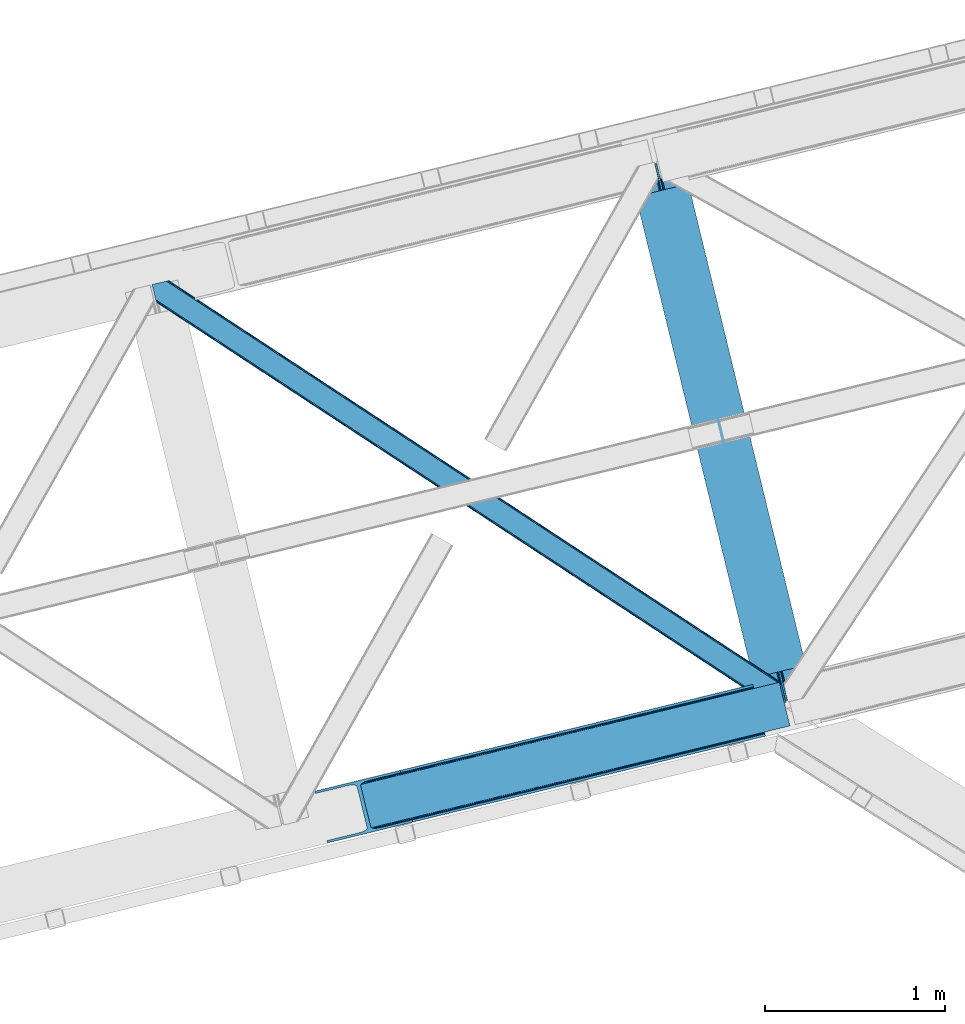
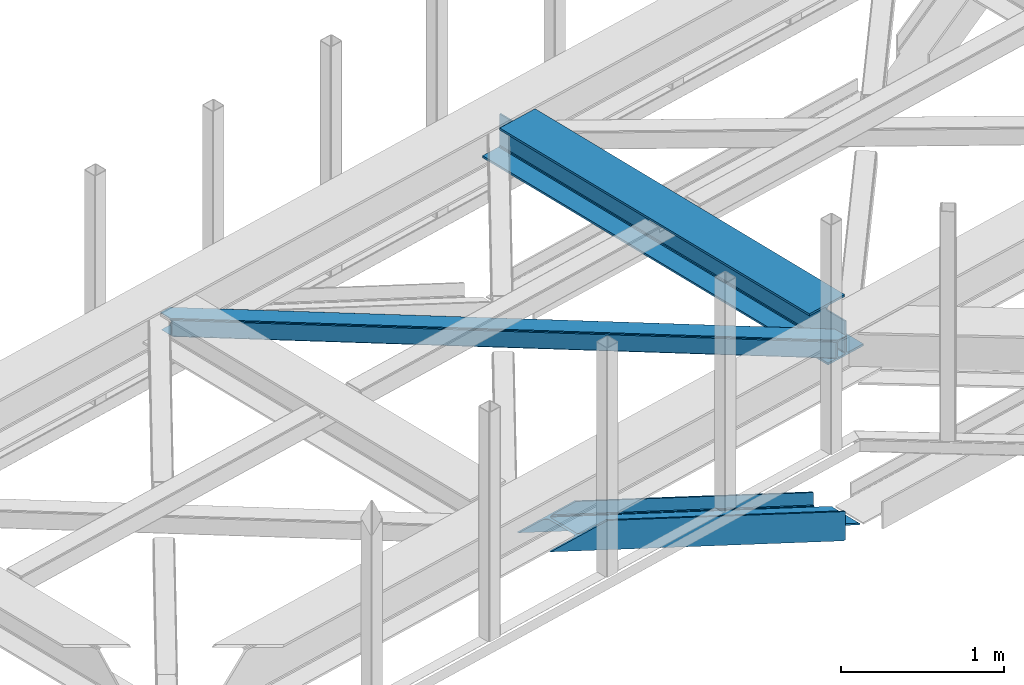
# One storey, part 56 of 66: 2 members, 1 beam.
"""IFC4 building model written with IfcOpenShell, lengths in millimetres."""

import ifcopenshell
import ifcopenshell.guid

model = None  # the IFC model being written
_history = None  # IfcOwnerHistory: only IFC2X3 demands one
_inside = {}  # id of a spatial element -> (the spatial element, [elements in it])
_under = {}  # id of a project, library or spatial element -> (it, [spatial elements below it])
_declared = {}  # id of a project -> (the project, [libraries it declares])
_typed = {}  # id of a type object -> (the type object, [elements of that type])
_made_of = {}  # id of a material, layer set ... -> (it, [elements and type objects made of it])


def new_model(schema):
    """Start an empty IFC model of exactly this schema.

    Asked for "IFC4X3", IfcOpenShell would pick the latest addendum, in which some entities
    have other attributes; the version numbers below select the first issue.
    IFC2X3 requires an IfcOwnerHistory on every rooted entity: one is made here for all.
    """
    global model, _history
    if schema == "IFC4X3":
        model = ifcopenshell.file(schema_version=(4, 3, 0, 0))
    else:
        model = ifcopenshell.file(schema=schema)
    _inside.clear()
    _under.clear()
    _declared.clear()
    _typed.clear()
    _made_of.clear()
    _history = None
    if model.schema == "IFC2X3":
        org = make("IfcOrganization", Name="unknown")
        user = make(
            "IfcPersonAndOrganization",
            ThePerson=make("IfcPerson", FamilyName="unknown"),
            TheOrganization=org,
        )
        app = make(
            "IfcApplication",
            ApplicationDeveloper=org,
            Version="unknown",
            ApplicationFullName="unknown",
            ApplicationIdentifier="unknown",
        )
        _history = make(
            "IfcOwnerHistory",
            OwningUser=user,
            OwningApplication=app,
            ChangeAction="ADDED",
            CreationDate=0,
        )
    return model


def make(cls, **values):
    """One entity of the class cls with the attributes given. An attribute that is None is left unset."""
    return model.create_entity(
        cls, **{name: value for name, value in values.items() if value is not None}
    )


def entity(cls, *values):
    """Any entity or typed value of the class cls, its attributes in the order of the schema. None: left unset."""
    e = model.create_entity(cls)
    for i, value in enumerate(values):
        if value is not None:
            e[i] = value
    return e


def rooted(cls, **values):
    """An entity with a GlobalId (a new one), such as an element, a storey or a relation."""
    return make(cls, GlobalId=ifcopenshell.guid.new(), OwnerHistory=_history, **values)


def si_unit(unit_type, name, prefix=None):
    """IfcSIUnit, for example si_unit("LENGTHUNIT", "METRE", prefix="MILLI")."""
    return make("IfcSIUnit", UnitType=unit_type, Prefix=prefix, Name=name)


def converted_unit(unit_type, name, factor, base, dimensions=None, offset=None):
    """IfcConversionBasedUnit, such as the inch: factor (a typed value) times the base unit."""
    return make(
        "IfcConversionBasedUnit"
        if offset is None
        else "IfcConversionBasedUnitWithOffset",
        ConversionOffset=offset,
        Dimensions=None
        if dimensions is None
        else entity("IfcDimensionalExponents", *dimensions),
        UnitType=unit_type,
        Name=name,
        ConversionFactor=make(
            "IfcMeasureWithUnit", ValueComponent=factor, UnitComponent=base
        ),
    )


def derived_unit(unit_type, elements):
    """IfcDerivedUnit: a product of units, each with its exponent."""
    return make(
        "IfcDerivedUnit",
        Elements=[
            make("IfcDerivedUnitElement", Unit=unit, Exponent=power)
            for unit, power in elements
        ],
        UnitType=unit_type,
    )


def assignment(units):
    """IfcUnitAssignment: the units of a project."""
    return None if units is None else make("IfcUnitAssignment", Units=units)


def point(xyz):
    """IfcCartesianPoint."""
    return None if xyz is None else make("IfcCartesianPoint", Coordinates=xyz)


def direction(xyz):
    """IfcDirection."""
    return None if xyz is None else make("IfcDirection", DirectionRatios=xyz)


def frame(location, z_axis=None, x_axis=None):
    """IfcAxis2Placement3D, a coordinate frame: its origin and axes. An axis left out is left unset."""
    return make(
        "IfcAxis2Placement3D",
        Location=point(location),
        Axis=direction(z_axis),
        RefDirection=direction(x_axis),
    )


def origin():
    """The frame at (0, 0, 0) with its axes left unset."""
    return frame((0.0, 0.0, 0.0))


def place(relative_to, where):
    """IfcLocalPlacement: puts the frame where relative to a parent placement (None: the world)."""
    return make(
        "IfcLocalPlacement", PlacementRelTo=relative_to, RelativePlacement=where
    )


def context(
    kind, dimensions, precision=None, world=None, true_north=None, identifier=None
):
    """IfcGeometricRepresentationContext, for example the 3D "Model" context."""
    return make(
        "IfcGeometricRepresentationContext",
        ContextIdentifier=identifier,
        ContextType=kind,
        CoordinateSpaceDimension=dimensions,
        Precision=precision,
        WorldCoordinateSystem=world,
        TrueNorth=true_north,
    )


def subcontext(parent, identifier, kind, view, scale=None):
    """IfcGeometricRepresentationSubContext, for example "Body" below "Model"."""
    return make(
        "IfcGeometricRepresentationSubContext",
        ContextIdentifier=identifier,
        ContextType=kind,
        ParentContext=parent,
        TargetScale=scale,
        TargetView=view,
    )


def project(units=None, contexts=None):
    """IfcProject with its units and contexts."""
    return rooted(
        "IfcProject",
        Name="project",
        RepresentationContexts=contexts,
        UnitsInContext=assignment(units),
    )


def spatial(cls, under=None, at=None, **own):
    """A site, building, storey or space (cls), placed at a placement, below another one or the project."""
    s = rooted(cls, ObjectPlacement=at, **own)
    if under is not None:
        _under.setdefault(under.id(), (under, []))[1].append(s)
    return s


def point_list(points):
    """IfcCartesianPointList2D or 3D."""
    cls = (
        "IfcCartesianPointList2D" if len(points[0]) == 2 else "IfcCartesianPointList3D"
    )
    return make(cls, CoordList=points)


def triangles(points, corners, closed=None, point_numbers=None):
    """IfcTriangulatedFaceSet: each triangle names its three corners, points numbered from 1."""
    return make(
        "IfcTriangulatedFaceSet",
        Coordinates=point_list(points),
        Closed=closed,
        CoordIndex=corners,
        PnIndex=point_numbers,
    )


def polygons(points, faces, closed=None, point_numbers=None):
    """IfcPolygonalFaceSet: a face is its outer loop, then its inner loops; points numbered from 1."""
    made = []
    for loops in faces:
        if len(loops) == 1:
            made.append(make("IfcIndexedPolygonalFace", CoordIndex=loops[0]))
        else:
            made.append(
                make(
                    "IfcIndexedPolygonalFaceWithVoids",
                    CoordIndex=loops[0],
                    InnerCoordIndices=loops[1:],
                )
            )
    return make(
        "IfcPolygonalFaceSet",
        Coordinates=point_list(points),
        Closed=closed,
        Faces=made,
        PnIndex=point_numbers,
    )


def shape(context_of_items, identifier, shape_type, items):
    """IfcShapeRepresentation: the items that make up one representation, for example the "Body"."""
    return make(
        "IfcShapeRepresentation",
        ContextOfItems=context_of_items,
        RepresentationIdentifier=identifier,
        RepresentationType=shape_type,
        Items=items,
    )


def material(Name=None, Category=None):
    """IfcMaterial."""
    return make("IfcMaterial", Name=Name, Category=Category)


def made_of(thing, what):
    """Note that an element or type object is made of a material, layer set ...; save() writes the relation."""
    if what is not None:
        _made_of.setdefault(what.id(), (what, []))[1].append(thing)
    return thing


def type_object(cls, material=None, **own):
    """A type object (cls), such as IfcWallType, which elements share."""
    return made_of(rooted(cls, **own), material)


def element(
    cls,
    number,
    at=None,
    inside=None,
    cuts=None,
    type_object=None,
    material=None,
    context=None,
    identifier="Body",
    shape_type=None,
    held_by="IfcProductDefinitionShape",
    body=None,
    shapes=None,
    **own,
):
    """One element of the class cls, such as IfcWall. Its Tag is "e" and its number.

    at: its placement. inside: the storey or other place that contains it. cuts: it is an
    opening in that element (IfcRelVoidsElement). A single representation is given by context,
    identifier, shape_type and body (its items); several are given by shapes. held_by: the class
    of the entity that holds the representations. save() writes the other relations.
    """
    e = rooted(cls, Tag="e%d" % number, ObjectPlacement=at, **own)
    if body is not None:
        shapes = [shape(context, identifier, shape_type, body)]
    if shapes is not None:
        e.Representation = make(held_by, Representations=shapes)
    if inside is not None:
        _inside.setdefault(inside.id(), (inside, []))[1].append(e)
    if cuts is not None:
        rooted(
            "IfcRelVoidsElement", RelatingBuildingElement=cuts, RelatedOpeningElement=e
        )
    if type_object is not None:
        _typed.setdefault(type_object.id(), (type_object, []))[1].append(e)
    return made_of(e, material)


def aggregate(whole, parts):
    """IfcRelAggregates: a whole, such as a stair, and the parts it consists of."""
    return rooted("IfcRelAggregates", RelatingObject=whole, RelatedObjects=parts)


def save(model, path):
    """Write the relations noted so far, then the file.

    IfcRelAggregates (storeys below a building ...), IfcRelContainedInSpatialStructure (elements
    in a storey), IfcRelDefinesByType, IfcRelAssociatesMaterial and IfcRelDeclares: one each for
    every whole, place, type object, material and project.
    """
    for whole, parts in _under.values():
        aggregate(whole, parts)
    for where, things in _inside.values():
        rooted(
            "IfcRelContainedInSpatialStructure",
            RelatedElements=things,
            RelatingStructure=where,
        )
    for kind, things in _typed.values():
        rooted("IfcRelDefinesByType", RelatedObjects=things, RelatingType=kind)
    for what, things in _made_of.values():
        rooted("IfcRelAssociatesMaterial", RelatedObjects=things, RelatingMaterial=what)
    for by, libraries in _declared.values():
        rooted("IfcRelDeclares", RelatingContext=by, RelatedDefinitions=libraries)
    model.write(path)


model = new_model("IFC4")

# Units and contexts
model_context = context("Model", 3, precision=0.01, world=origin(), true_north=direction((6.12303176911189e-17, 1.0)))
plan_context = context("Plan", 3, precision=0.01, world=origin(), true_north=direction((6.12303176911189e-17, 1.0)))
body_context = subcontext(model_context, "Body", "Model", "MODEL_VIEW")
ifc_project = project(units=[si_unit("LENGTHUNIT", "METRE", prefix="MILLI"), si_unit("AREAUNIT", "SQUARE_METRE"), si_unit("VOLUMEUNIT", "CUBIC_METRE"), converted_unit("PLANEANGLEUNIT", "DEGREE", entity("IfcRatioMeasure", 0.0174532925199433), si_unit("PLANEANGLEUNIT", "RADIAN"), dimensions=[0, 0, 0, 0, 0, 0, 0]), si_unit("MASSUNIT", "GRAM", prefix="KILO"), derived_unit("MASSDENSITYUNIT", [(si_unit("MASSUNIT", "GRAM", prefix="KILO"), 1), (si_unit("LENGTHUNIT", "METRE"), -3)]), derived_unit("MOMENTOFINERTIAUNIT", [(si_unit("LENGTHUNIT", "METRE"), 4)]), si_unit("TIMEUNIT", "SECOND"), si_unit("FREQUENCYUNIT", "HERTZ"), si_unit("THERMODYNAMICTEMPERATUREUNIT", "DEGREE_CELSIUS"), derived_unit("THERMALTRANSMITTANCEUNIT", [(si_unit("MASSUNIT", "GRAM", prefix="KILO"), 1), (si_unit("THERMODYNAMICTEMPERATUREUNIT", "KELVIN"), -1), (si_unit("TIMEUNIT", "SECOND"), -3)]), derived_unit("VOLUMETRICFLOWRATEUNIT", [(si_unit("LENGTHUNIT", "METRE"), 3), (si_unit("TIMEUNIT", "SECOND"), -1)]), derived_unit("MASSFLOWRATEUNIT", [(si_unit("MASSUNIT", "GRAM", prefix="KILO"), 1), (si_unit("TIMEUNIT", "SECOND"), -1)]), derived_unit("ROTATIONALFREQUENCYUNIT", [(si_unit("TIMEUNIT", "SECOND"), -1)]), si_unit("ELECTRICCURRENTUNIT", "AMPERE"), si_unit("ELECTRICVOLTAGEUNIT", "VOLT"), si_unit("POWERUNIT", "WATT"), si_unit("FORCEUNIT", "NEWTON", prefix="KILO"), si_unit("ILLUMINANCEUNIT", "LUX"), si_unit("LUMINOUSFLUXUNIT", "LUMEN"), si_unit("LUMINOUSINTENSITYUNIT", "CANDELA"), derived_unit("USERDEFINED", [(si_unit("MASSUNIT", "GRAM", prefix="KILO"), -1), (si_unit("LENGTHUNIT", "METRE"), -2), (si_unit("TIMEUNIT", "SECOND"), 3), (si_unit("LUMINOUSFLUXUNIT", "LUMEN"), 1)]), derived_unit("LINEARVELOCITYUNIT", [(si_unit("LENGTHUNIT", "METRE"), 1), (si_unit("TIMEUNIT", "SECOND"), -1)]), si_unit("PRESSUREUNIT", "PASCAL"), derived_unit("USERDEFINED", [(si_unit("LENGTHUNIT", "METRE"), -2), (si_unit("MASSUNIT", "GRAM", prefix="KILO"), 1), (si_unit("TIMEUNIT", "SECOND"), -2)]), derived_unit("LINEARFORCEUNIT", [(si_unit("MASSUNIT", "GRAM", prefix="KILO"), 1), (si_unit("LENGTHUNIT", "METRE"), 1), (si_unit("TIMEUNIT", "SECOND"), -2), (si_unit("LENGTHUNIT", "METRE"), -1)]), derived_unit("PLANARFORCEUNIT", [(si_unit("MASSUNIT", "GRAM", prefix="KILO"), 1), (si_unit("LENGTHUNIT", "METRE"), 1), (si_unit("TIMEUNIT", "SECOND"), -2), (si_unit("LENGTHUNIT", "METRE"), -2)])], contexts=[model_context, plan_context])

# Site, building, storey
site_placement = place(None, origin())
site = spatial("IfcSite", under=ifc_project, at=site_placement, CompositionType="ELEMENT")
building_placement = place(site_placement, origin())
building = spatial("IfcBuilding", under=site, at=building_placement, CompositionType="ELEMENT")
storey_placement = place(building_placement, frame((0.0, 0.0, 19800.0)))
storey = spatial("IfcBuildingStorey", under=building, at=storey_placement, Name="06", CompositionType="ELEMENT", Elevation=19800.0)

# Beam
ifc_material = material(Name="Metal painted (White)")
beam_type = type_object("IfcBeamType", PredefinedType="BEAM")
beam_placement = place(storey_placement, frame((-6288.26, 16262.1, 3807.02)))
element("IfcBeam", 1, at=beam_placement, inside=storey, type_object=beam_type, material=ifc_material, ObjectType="Steel Beam", PredefinedType="BEAM", context=body_context, shape_type="Tessellation", body=[
    polygons([(1018.1664837833, 71.0478278971021, 15.5000000000008), (1018.1664837833, 71.0478278971021, 0.0), (291.465617442446, 3052.25531830421, 0.0), (291.465617442446, 3052.25531830421, 15.5000000000008), (894.779372399328, 40.970914087327, 15.5000000000008), (168.078506058477, 3022.17840449444, 15.5000000000008), (888.08702862538, 39.3395844888265, 16.8701684147984), (161.386162284532, 3020.54707489594, 16.8701684147984), (882.413533524755, 37.956610033654, 20.7720779386478), (155.712667183905, 3019.16410044076, 20.7720779386478), (878.622625296183, 37.0325360459184, 26.6116982174294), (151.921758955332, 3018.24002645303, 26.6116982174294), (877.291435352789, 36.7080444135029, 33.500000000001), (150.590569011938, 3017.91553482062, 33.500000000001), (140.875048430522, 3015.54727389071, 33.500000000001), (140.875048430529, 3015.54727389071, 259.000000000002), (150.590569011936, 3017.91553482062, 259.000000000002), (0.0, 2981.20749040711, 0.0), (3.24860138789518e-12, 2981.20749040711, 15.4999999999965), (123.387111383973, 3011.28440421689, 15.5000000000008), (130.079455157929, 3012.91573381539, 16.8701684147984), (135.752950258543, 3014.29870827056, 20.7720779386391), (139.543858487125, 3015.2227822583, 26.6116982174294), (877.291435352786, 36.7080444135051, 259.000000000002), (867.575914771381, 34.3397834836014, 259.000000000002), (867.575914771373, 34.3397834836014, 33.500000000001), (866.244724827976, 34.0152918511859, 26.6116982174294), (862.453816599394, 33.0912178634502, 20.7720779386391), (856.780321498778, 31.70824340828, 16.8701684147984), (850.087977724824, 30.076913809773, 15.5000000000008), (726.700866340854, 0.0, 15.4999999999965), (726.700866340851, 0.0, 0.0), (838.124523615913, 197.385937999179, 259.069791973884), (186.469722099971, 2870.72539801218, 259.000000000002), (186.693115201822, 2869.8089536072, 259.617303331124), (186.70550404545, 2869.75812937344, 266.500003008253), (837.979344808147, 197.981416001704, 266.500002998871), (837.979694928899, 197.979979696973, 260.000004007589), (828.499586345894, 194.645865944436, 259.006343171919), (828.276216326132, 195.562317481916, 259.617303331124), (828.263827482502, 195.613141715689, 266.500003008253), (176.989986719804, 2867.38985508742, 266.500002998871), (176.989636599053, 2867.39129139215, 260.000004007589), (176.844830940719, 2867.98534020595, 259.07612046749), (176.75420151856, 2868.35713708228, 259.000000000002), (839.310832678078, 198.30468544639, 273.388305639783), (843.101109266765, 199.231350618303, 279.227924098781), (848.774180214308, 200.616065081983, 283.129832400619), (855.466371895431, 202.248018612794, 284.500000377224), (978.853400583268, 232.325271667905, 284.500000138971), (978.851730776622, 232.332121736639, 299.999995328161), (687.386308679347, 161.283492472594, 299.999995890962), (687.387978486002, 161.276642403863, 284.500000701776), (810.77500717385, 191.353895458972, 284.500000463519), (817.467494069993, 192.984637925553, 283.129832461069), (823.141405718744, 194.365903570079, 279.227924137322), (826.932940505748, 195.287407219375, 273.388305663684), (175.658498849865, 2867.06658564273, 273.388305639783), (171.868222261161, 2866.13992047082, 279.227924098781), (166.195151313634, 2864.75520600714, 283.129832400619), (159.502959632503, 2863.12325247633, 284.500000377228), (36.1159309446587, 2833.04599942122, 284.500000138971), (36.117600751305, 2833.03914935249, 299.999995328161), (327.583022848579, 2904.08777861653, 299.999995890962), (327.581353041926, 2904.09462868526, 284.500000701776), (204.194324354083, 2874.01737563015, 284.500000463519), (197.501837457949, 2872.38663316357, 283.129832461069), (191.827925809181, 2871.00536751904, 279.227924137318), (188.036391022195, 2870.08386386975, 273.388305663684)], [[[1, 2, 3, 4]], [[5, 1, 4, 6]], [[7, 5, 6, 8]], [[9, 7, 8, 10]], [[11, 9, 10, 12]], [[13, 11, 12, 14]], [[15, 16, 17, 14, 12, 10, 8, 6, 4, 3, 18, 19, 20, 21, 22, 23]], [[13, 24, 25, 26, 27, 28, 29, 30, 31, 32, 2, 1, 5, 7, 9, 11]], [[2, 32, 18, 3]], [[32, 31, 19, 18]], [[31, 30, 20, 19]], [[27, 26, 15, 23]], [[28, 27, 23, 22]], [[29, 28, 22, 21]], [[30, 29, 21, 20]], [[33, 24, 13, 14, 17, 34, 35, 36, 37, 38]], [[25, 39, 40, 41, 42, 43, 44, 16, 15, 26]], [[39, 25, 24, 33]], [[45, 34, 17, 16]], [[41, 40, 38, 37, 46, 47, 48, 49, 50, 51, 52, 53, 54, 55, 56, 57]], [[42, 58, 59, 60, 61, 62, 63, 64, 65, 66, 67, 68, 69, 36, 35, 43]], [[46, 37, 36, 69]], [[47, 46, 69, 68]], [[48, 47, 68, 67]], [[49, 48, 67, 66]], [[50, 49, 66, 65]], [[51, 50, 65, 64]], [[52, 51, 64, 63]], [[53, 52, 63, 62]], [[54, 53, 62, 61]], [[55, 54, 61, 60]], [[56, 55, 60, 59]], [[57, 56, 59, 58]], [[41, 57, 58, 42]]], closed=False),
])

# Members
member_type_1 = type_object("IfcMemberType", PredefinedType="BRACE")
member_1_placement = place(storey_placement, frame((-8033.12, 15508.63, 2584.39)))
element("IfcMember", 2, at=member_1_placement, inside=storey, type_object=member_type_1, ObjectType="Steel Vertical Brace", PredefinedType="BRACE", context=body_context, shape_type="Tessellation", body=[
    triangles([(2635.93561706543, 649.181304931641, 33.9583923339851), (2634.040965271, 656.954086303711, 33.9583923339851), (2635.12520141602, 650.127758789064, 32.7096313476541), (2635.1856628418, 648.998757934571, 32.2491943359382), (2635.93561706543, 649.181304931641, 45.3390930175774), (2495.05991363525, 614.841540527344, 97.2405761718728), (2495.05991363525, 614.841540527344, 110.67696533203), (2634.040965271, 656.954086303711, 43.2810791015618), (309.064274597168, 90.2154235839844, 1121.6082824707), (313.935488891601, 84.3134582519542, 1121.6082824707), (2635.65947113037, 650.313793945314, 45.0391113281257), (324.545306396484, 80.8892486572277, 1121.6082824707), (2496.17961273193, 610.247634887695, 114.402319335935), (2497.10397491455, 606.457168579102, 120.806579589844), (339.278128051758, 80.4636932373051, 1121.6082824707), (2497.42837371826, 605.125854492188, 128.361932373045), (355.892230224609, 83.1042297363292, 1121.6082824707), (2497.42837371826, 605.125854492188, 213.642773437499), (539.761820983887, 127.923587036134, 1121.6082824707), (2500.5072555542, 592.495230102541, 213.642773437499), (542.840702819824, 115.294125366212, 1121.6082824707), (2578.86061248779, 883.325152587891, 43.2810791015618), (253.883921813965, 316.587652587892, 1121.6082824707), (2500.5072555542, 592.495230102541, 2.47891845702907), (2497.42837371826, 605.125854492188, 79.5532836914063), (2497.42837371826, 605.125854492188, 2.47891845702907), (2497.10397491455, 606.457168579102, 87.1086364746079), (2496.17961273193, 610.247634887695, 93.5152221679673), (287.352809143066, 77.833621215821, 1121.6082824707), (279.509101867676, 69.9108489990249, 1121.6082824707), (288.961431884766, 85.3157226562507, 1121.6082824707), (266.619772338868, 62.7531463623054, 1121.6082824707), (250.654467773437, 57.4511444091804, 1121.6082824707), (2488.16672973633, 589.487274169922, 0.0), (69.8637588500978, 0.0, 1121.6082824707), (2485.08784790039, 602.117898559571, 0.0), (66.78487701416, 12.6306243896488, 1121.6082824707), (2578.86061248779, 883.325152587891, 33.9583923339851), (233.781079101563, 311.686788940431, 1121.6082824707), (2576.96596069336, 891.097933959962, 33.9583923339851), (2577.24210662842, 889.964282226563, 45.0391113281257), (2576.96596069336, 891.097933959962, 45.3390930175774), (2576.68225708008, 889.884054565431, 32.7096313476541), (2576.21542510986, 890.91538696289, 32.2491943359382), (2436.09025726318, 856.758169555666, 97.2405761718728), (2436.09025726318, 856.758169555666, 110.67696533203), (255.492544555665, 324.069754028322, 1121.6082824707), (263.336251831055, 331.992526245118, 1121.6082824707), (2434.9705581665, 861.350912475587, 114.402319335935), (2434.04677734375, 865.142541503907, 120.806579589844), (276.220930480958, 339.14906616211, 1121.6082824707), (2433.72179718018, 866.472692871095, 128.361932373045), (292.186235046387, 344.451068115235, 1121.6082824707), (2434.9705581665, 861.350912475587, 93.5152221679673), (228.909864807129, 317.589916992189, 1121.6082824707), (218.299465942383, 321.014126586915, 1121.6082824707), (2433.72179718018, 866.472692871095, 79.5532836914063), (2434.04677734375, 865.142541503907, 87.1086364746079), (203.562574768067, 321.43851928711, 1121.6082824707), (186.948472595215, 318.797982788086, 1121.6082824707), (2433.72179718018, 866.472692871095, 213.642773437499), (476.055825805664, 389.271588134767, 1121.6082824707), (2430.6434967041, 879.103317260742, 213.642773437499), (472.976943969727, 401.901049804688, 1121.6082824707), (0.0, 286.608087158203, 1121.6082824707), (3.07888183593786, 273.978625488282, 1121.6082824707), (2430.6434967041, 879.103317260742, 2.47891845702907), (2433.72179718018, 866.472692871095, 2.47891845702907), (2418.30297088623, 876.095361328127, 0.0), (2421.38185272217, 863.464736938477, 0.0)], [[1, 2, 3], [3, 4, 1], [4, 5, 6], [5, 4, 1], [7, 6, 5], [8, 9, 10], [11, 10, 7], [7, 10, 12], [12, 13, 7], [7, 5, 11], [14, 13, 15], [12, 15, 13], [16, 14, 17], [15, 17, 14], [10, 11, 8], [18, 16, 19], [17, 19, 16], [20, 18, 21], [19, 21, 18], [8, 22, 23], [23, 9, 8], [24, 25, 16], [26, 25, 24], [16, 25, 14], [16, 20, 24], [18, 20, 16], [14, 25, 27], [27, 28, 13], [28, 6, 13], [7, 13, 6], [13, 14, 27], [29, 3, 6], [6, 30, 29], [6, 28, 30], [3, 4, 6], [2, 3, 31], [29, 31, 3], [28, 27, 30], [32, 30, 27], [27, 25, 32], [33, 32, 25], [34, 20, 21], [20, 34, 24], [21, 35, 34], [25, 36, 33], [25, 26, 36], [37, 33, 36], [36, 34, 35], [35, 37, 36], [26, 24, 36], [34, 36, 24], [38, 2, 39], [31, 39, 2], [22, 38, 8], [40, 22, 41], [22, 40, 38], [41, 42, 40], [2, 8, 38], [8, 1, 11], [1, 8, 2], [5, 11, 1], [38, 40, 43], [44, 43, 40], [42, 44, 45], [42, 40, 44], [45, 46, 42], [47, 41, 46], [46, 48, 47], [46, 49, 48], [41, 42, 46], [22, 41, 47], [47, 23, 22], [49, 50, 51], [51, 48, 49], [50, 52, 53], [53, 51, 50], [54, 45, 55], [55, 56, 54], [57, 58, 59], [59, 60, 57], [58, 54, 56], [56, 59, 58], [44, 43, 45], [55, 45, 43], [43, 38, 39], [39, 55, 43], [52, 61, 62], [62, 53, 52], [61, 63, 62], [64, 62, 63], [9, 23, 31], [48, 51, 59], [53, 64, 65], [62, 64, 53], [51, 53, 60], [23, 47, 55], [47, 48, 56], [12, 32, 15], [21, 17, 35], [17, 15, 33], [21, 19, 17], [12, 10, 30], [10, 9, 29], [31, 23, 39], [60, 59, 51], [55, 47, 56], [59, 56, 48], [55, 39, 23], [65, 60, 53], [65, 66, 60], [33, 15, 32], [30, 10, 29], [31, 29, 9], [30, 32, 12], [33, 35, 17], [35, 33, 37], [50, 58, 57], [45, 54, 49], [54, 58, 49], [50, 49, 58], [49, 46, 45], [57, 67, 52], [67, 57, 68], [63, 52, 67], [57, 52, 50], [63, 61, 52], [63, 69, 64], [63, 67, 69], [65, 64, 69], [70, 57, 60], [57, 70, 68], [60, 66, 70], [69, 70, 65], [66, 65, 70], [67, 68, 69], [70, 69, 68]]),
])
member_type_2 = type_object("IfcMemberType", PredefinedType="BRACE")
member_2_placement = place(storey_placement, frame((-8936.9, 16267.7, 3823.0)))
element("IfcMember", 3, at=member_2_placement, inside=storey, type_object=member_type_2, ObjectType="Steel Horizontal Brace", PredefinedType="BRACE", context=body_context, shape_type="Tessellation", body=[
    triangles([(2937.3747756958, 494.994204711913, 17.5012573242202), (3489.95558166504, 132.252392578126, 122.499499511719), (3489.95558166504, 132.252392578126, 17.5012573242202), (2363.74234771729, 871.557266235353, 17.5012573242202), (1790.1046875, 1248.11916503906, 17.5012573242202), (93.3082580566406, 2361.98373413086, 122.499499511719), (642.839250183106, 2001.24645080566, 17.5012573242202), (93.3082580566406, 2361.98373413086, 17.5012573242202), (1216.47167816162, 1624.68338928223, 17.5012573242202), (3496.03021087647, 107.330657958984, 140.00075683594), (3493.7053527832, 116.868447875977, 138.668280029298), (70.0556076049816, 2356.31547546387, 140.00075683594), (78.9527389526374, 2358.48394775391, 138.668280029298), (3491.73454284668, 124.952838134765, 134.87548828125), (86.4987899780281, 2360.32337036133, 134.87548828125), (3490.41776275635, 130.355996704102, 129.196765136719), (91.5368545532237, 2361.55236511231, 129.196765136719), (18.1488922119152, 2264.78501586914, 140.00075683594), (0.0, 2339.23861083984, 140.00075683594), (3459.56150665283, 5.66825866699219, 140.00075683594), (3517.37658233643, 19.761584472657, 140.00075683594), (3436.30885620117, 0.0, 122.499499511719), (3438.08025970459, 0.431369018555415, 129.196765136719), (24.2235214233406, 2239.86328125, 122.499499511719), (23.761340332032, 2241.75967712402, 129.196765136719), (3443.11832427979, 1.66036376953161, 134.87548828125), (22.4445602416999, 2247.16283569336, 134.87548828125), (3450.66437530518, 3.49978637695313, 138.668280029298), (20.4737503051765, 2255.24722595215, 138.668280029298), (1731.79080505371, 1118.9293762207, 17.5012573242202), (2308.03237609863, 740.658279418947, 17.5012573242202), (2884.26987762451, 362.387182617187, 17.5012573242202), (3436.30885620117, 0.0, 17.5012573242202), (1155.5538848877, 1497.20163574219, 17.5012573242202), (579.31696472168, 1875.47389526367, 17.5012573242202), (24.2235214233406, 2239.86328125, 17.5012573242202), (21.3312561035164, 2251.72883605957, 122.197192382813), (20.0144760131843, 2257.13083190918, 127.873590087893), (21.7934371948249, 2249.83127746582, 115.499926757813), (21.7934371948249, 2249.83127746582, 24.5008300781265), (21.3312561035164, 2251.72883605957, 17.8035644531265), (20.1470260620117, 2256.58667907715, 12.5201660156272), (23.9723739624023, 2240.89345092773, 12.5201660156272), (18.0436660766609, 2265.2163848877, 131.668707275392), (15.7188079833995, 2274.75301208496, 133.001184082033), (0.0, 2339.23861083984, 133.001184082033), (3468.86500854492, 7.93556213378906, 133.001184082033), (3459.96322631836, 5.76592712402453, 131.668707275392), (3452.42182617188, 3.92766723632849, 127.873590087893), (3447.37911071777, 2.69867248535229, 122.197192382813), (3445.60770721436, 2.26730346679688, 115.499926757813), (3445.60770721436, 2.26730346679688, 24.5008300781265), (60.7521057128906, 2354.04817199707, 133.001184082033), (3498.46029510498, 97.3626617431637, 133.001184082033), (3517.37658233643, 19.761584472657, 133.001184082033), (23.177655029298, 2261.84798583984, 8.3320495605476), (3452.42182617188, 3.92766723632849, 12.1248413085959), (3447.37911071777, 2.69867248535229, 17.8035644531265), (3459.96322631836, 5.76592712402453, 8.3320495605476), (3468.86500854492, 7.93556213378906, 6.99957275390625), (22.4835113525387, 2270.31258544922, 6.99957275390625), (31.1539123535167, 2240.98763122559, 5.52059326172093), (6.80016632080151, 2340.89664916992, 5.52059326172093), (5.36304473876953, 2340.54667053223, 6.99957275390625), (25.5711135864258, 2240.91437988281, 10.9621215820334), (3492.38508453369, 122.284396362304, 115.499926757813), (3492.84784698486, 120.386837768556, 122.197192382813), (82.2380035400402, 2359.28506164551, 122.197192382813), (84.0047561645515, 2359.71526794434, 115.499926757813), (3494.1646270752, 114.984841918946, 127.873590087893), (77.1952880859371, 2358.05606689453, 127.873590087893), (3496.13543701172, 106.899288940431, 131.668707275392), (69.6533065795902, 2356.21780700683, 131.668707275392), (60.7521057128906, 2354.04817199707, 6.99957275390625), (87.0045730590828, 2360.44661865234, 5.52059326172093), (69.6533065795902, 2356.21780700683, 8.3320495605476), (82.2380035400402, 2359.28506164551, 17.8035644531265), (77.1952880859371, 2358.05606689453, 12.1248413085959), (84.0047561645515, 2359.71526794434, 24.5008300781265), (91.5368545532237, 2361.55236511231, 10.8039916992202), (3492.38508453369, 122.284396362304, 24.5008300781265), (3490.20672912598, 131.222222900391, 12.5201660156272), (3492.84784698486, 120.386837768556, 17.8035644531265), (3494.03207702637, 115.528994750977, 12.5201660156272), (3491.69559173584, 101.803088378907, 6.99957275390625), (3512.01295623779, 18.4535247802742, 6.99957275390625), (3491.00144805908, 110.267687988282, 8.3320495605476), (3442.61195983887, 1.53595275878979, 5.52059326172093), (3438.08025970459, 0.431369018555415, 10.8039916992202), (3510.57583465576, 18.1035461425781, 5.52059326172093), (3483.024609375, 131.129205322266, 5.52059326172093), (3488.60798950195, 131.201293945314, 10.9621215820334), (31.1539123535167, 2240.98763122559, 5.43687744140698), (87.0045730590828, 2360.44661865234, 5.55547485351781), (164.75099029541, 2309.41019897461, 5.51594238281177), (6.80016632080151, 2340.89664916992, 5.52989501953198), (146.797434997559, 2165.60502319336, 5.37874145507885), (196.831590270996, 2177.801953125, 5.39734497070458), (163.159226989746, 2169.5943145752, 0.0), (196.831590270996, 2177.801953125, 5.52059326172093), (197.80304260254, 2178.03914794922, 0.0), (146.797434997559, 2165.60618591309, 5.21363525390552), (154.262095642091, 2167.42467956543, 1.33247680664135), (197.80304260254, 2178.03914794922, 4.52065429687718), (166.329963684082, 2307.15452270508, 4.52065429687718), (170.404133605958, 2290.43926391602, 0.0), (168.079856872559, 2299.97589111328, 1.33247680664135), (3361.49423675537, 210.37553100586, 5.21363525390552), (2936.64575042725, 493.881481933595, 10.8039916992202), (2934.56099395752, 490.70958251953, 5.12526855468968), (3354.03422698975, 208.557037353517, 1.33247680664135), (640.024887084961, 1996.96066589355, 5.12526855468968), (636.907635498048, 1992.21444396973, 1.33247680664135), (642.105574035644, 2000.13140258789, 10.8039916992202), (165.5428024292, 2308.28236083984, 5.02062377929906), (164.75099029541, 2309.41019897461, 5.52059326172093), (633.231115722656, 1986.6147857666, 0.0), (3345.13244476318, 206.387402343751, 0.0), (2931.44781188965, 485.963360595704, 1.33247680664135), (2927.77187347412, 480.364865112306, 0.0), (2363.00867156982, 870.443380737304, 10.8039916992202), (1789.37566223145, 1247.00644226074, 10.8039916992202), (1215.73800201416, 1623.56834106445, 10.8039916992202), (2360.928565979, 867.272644042971, 5.12526855468968), (1787.29090576172, 1243.83454284668, 5.12526855468968), (1213.65789642334, 1620.39760437012, 5.12526855468968), (2357.81073303223, 862.526422119141, 1.33247680664135), (1784.17772369385, 1239.08948364258, 1.33247680664135), (1210.54471435547, 1615.65254516601, 1.33247680664135), (2354.13886413574, 856.927926635743, 0.0), (1780.50178527832, 1233.48982543945, 0.0), (1206.86877593994, 1610.05288696289, 0.0), (588.919866943359, 1890.10323486328, 0.0), (1165.15678710938, 1511.8309753418, 0.0), (1741.39428863525, 1133.55871582031, 0.0), (2893.87277984619, 377.016522216798, 0.0), (2317.63585968018, 755.287619018554, 0.0), (3315.15636749268, 199.079708862306, 0.0), (3343.77438812256, 81.6775726318356, 0.0), (2884.99890289307, 363.499905395509, 10.8039916992202), (2887.07900848389, 366.670642089843, 5.12526855468968), (3348.63630065918, 63.8333129882813, 5.02062377929906), (580.045989990234, 1876.58661804199, 10.8039916992202), (582.130746459961, 1879.75851745605, 5.12526855468968), (2890.19684143066, 371.416864013672, 1.33247680664135), (3346.09924621582, 72.1397827148448, 1.33247680664135), (3347.8491394043, 64.9611511230469, 4.52065429687718), (585.243928527832, 1884.50473937988, 1.33247680664135), (3349.42811279297, 62.7054748535156, 5.52059326172093), (2313.95933990479, 749.689123535156, 1.33247680664135), (1737.72241973877, 1127.96138305664, 1.33247680664135), (1161.48084869385, 1506.2324798584, 1.33247680664135), (2310.84208831787, 744.94290161133, 5.12526855468968), (1734.60458679199, 1123.21516113281, 5.12526855468968), (1158.36766662598, 1501.48625793457, 5.12526855468968), (2308.76198272705, 741.772164916993, 10.8039916992202), (1732.52448120117, 1120.04442443848, 10.8039916992202), (1156.28756103516, 1498.31552124024, 10.8039916992202), (3349.42811279297, 62.7054748535156, 5.51129150390625), (3361.49423675537, 210.37553100586, 5.38339233398438), (3483.024609375, 131.129205322266, 5.43687744140698), (3316.12781982422, 199.316903686524, 5.39734497070458), (3442.61195983887, 1.53595275878979, 5.55314941406323), (3510.57583465576, 18.1035461425781, 5.53222045898656), (3316.12781982422, 199.316903686524, 5.52059326172093), (3315.15636749268, 199.079708862306, 4.52065429687718)], [[1, 2, 3], [2, 1, 4], [2, 5, 6], [5, 2, 4], [7, 8, 6], [9, 6, 5], [6, 9, 7], [10, 11, 12], [13, 12, 11], [11, 14, 13], [15, 13, 14], [14, 16, 15], [17, 15, 16], [16, 2, 17], [6, 17, 2], [12, 18, 10], [12, 19, 18], [20, 10, 18], [21, 10, 20], [22, 23, 24], [25, 24, 23], [23, 26, 25], [27, 25, 26], [26, 28, 27], [29, 27, 28], [28, 20, 29], [18, 29, 20], [30, 22, 24], [22, 31, 32], [30, 31, 22], [32, 33, 22], [34, 24, 35], [24, 34, 30], [36, 35, 24], [37, 27, 38], [39, 40, 24], [25, 37, 24], [37, 25, 27], [37, 39, 24], [40, 36, 24], [41, 42, 43], [43, 36, 41], [40, 41, 36], [44, 29, 18], [19, 45, 18], [46, 45, 19], [44, 38, 29], [29, 38, 27], [45, 44, 18], [47, 48, 44], [44, 45, 47], [48, 49, 38], [38, 44, 48], [49, 50, 37], [37, 38, 49], [50, 51, 39], [39, 37, 50], [51, 52, 39], [40, 39, 52], [45, 53, 54], [53, 45, 46], [54, 47, 45], [55, 47, 54], [56, 42, 57], [57, 42, 41], [52, 58, 40], [41, 40, 58], [41, 58, 57], [57, 59, 56], [59, 60, 61], [61, 56, 59], [62, 61, 63], [61, 62, 56], [64, 63, 61], [42, 56, 62], [65, 43, 42], [65, 42, 62], [66, 67, 68], [68, 69, 66], [67, 70, 71], [71, 68, 67], [70, 72, 73], [73, 71, 70], [72, 54, 53], [53, 73, 72], [13, 12, 73], [19, 53, 12], [53, 19, 46], [53, 73, 12], [71, 13, 73], [71, 15, 13], [15, 68, 17], [68, 15, 71], [6, 68, 69], [68, 6, 17], [74, 75, 76], [77, 78, 75], [78, 76, 75], [74, 63, 75], [63, 74, 64], [79, 77, 8], [80, 8, 77], [6, 79, 8], [79, 6, 69], [77, 75, 80], [81, 66, 79], [69, 79, 66], [70, 14, 11], [14, 70, 67], [54, 72, 10], [72, 70, 11], [55, 54, 21], [10, 21, 54], [72, 11, 10], [82, 83, 84], [3, 2, 81], [81, 83, 3], [82, 3, 83], [2, 66, 81], [67, 16, 14], [2, 16, 67], [66, 2, 67], [74, 61, 85], [74, 64, 61], [60, 85, 61], [86, 85, 60], [78, 84, 83], [87, 84, 78], [85, 87, 76], [76, 74, 85], [78, 76, 87], [83, 77, 78], [83, 81, 77], [79, 77, 81], [49, 48, 28], [26, 49, 28], [50, 26, 23], [50, 22, 51], [26, 50, 49], [22, 50, 23], [48, 20, 28], [21, 47, 55], [21, 20, 47], [48, 47, 20], [22, 52, 51], [88, 57, 58], [58, 52, 33], [33, 52, 22], [58, 89, 88], [89, 58, 33], [90, 60, 88], [60, 59, 88], [59, 57, 88], [90, 86, 60], [84, 91, 92], [87, 91, 84], [92, 82, 84], [86, 90, 85], [85, 91, 87], [91, 85, 90], [93, 94, 95], [94, 93, 96], [95, 97, 93], [98, 97, 95], [99, 100, 101], [102, 99, 103], [101, 100, 104], [102, 100, 99], [105, 106, 104], [106, 105, 107], [101, 104, 106], [1, 82, 92], [1, 3, 82], [92, 91, 108], [108, 109, 92], [110, 108, 111], [112, 113, 107], [107, 105, 112], [114, 112, 115], [7, 114, 8], [80, 8, 114], [114, 116, 80], [75, 80, 116], [105, 115, 112], [113, 117, 106], [106, 107, 113], [111, 118, 119], [120, 119, 118], [111, 119, 110], [108, 110, 109], [92, 109, 1], [1, 109, 4], [121, 4, 109], [4, 121, 5], [122, 5, 121], [5, 122, 9], [123, 9, 122], [9, 123, 7], [114, 7, 123], [109, 110, 121], [124, 121, 110], [121, 124, 122], [125, 122, 124], [122, 125, 123], [126, 123, 125], [123, 126, 114], [112, 114, 126], [110, 119, 124], [127, 124, 119], [124, 127, 128], [128, 125, 124], [125, 128, 129], [129, 126, 125], [126, 129, 113], [113, 112, 126], [119, 120, 130], [130, 127, 119], [127, 130, 128], [131, 128, 130], [128, 131, 129], [132, 129, 131], [129, 132, 113], [117, 113, 132], [133, 99, 101], [117, 133, 101], [117, 101, 106], [132, 133, 117], [134, 133, 132], [131, 134, 132], [134, 131, 135], [120, 136, 137], [135, 130, 137], [130, 135, 131], [130, 120, 137], [120, 138, 136], [136, 138, 139], [118, 138, 120], [140, 141, 142], [35, 43, 65], [35, 36, 43], [65, 62, 102], [102, 143, 65], [144, 102, 103], [141, 145, 146], [146, 147, 141], [147, 142, 141], [139, 146, 145], [145, 136, 139], [133, 148, 99], [103, 99, 148], [103, 148, 144], [102, 144, 143], [65, 143, 35], [89, 33, 140], [32, 140, 33], [88, 89, 149], [140, 149, 89], [136, 145, 137], [150, 137, 145], [137, 150, 135], [151, 135, 150], [135, 151, 134], [152, 134, 151], [134, 152, 133], [148, 133, 152], [145, 141, 153], [153, 150, 145], [150, 153, 154], [154, 151, 150], [151, 154, 155], [155, 152, 151], [152, 155, 148], [144, 148, 155], [141, 140, 153], [156, 153, 140], [153, 156, 154], [157, 154, 156], [154, 157, 155], [158, 155, 157], [155, 158, 143], [143, 144, 155], [140, 32, 31], [31, 156, 140], [156, 31, 30], [30, 157, 156], [157, 30, 34], [34, 158, 157], [158, 34, 143], [35, 143, 34], [159, 160, 161], [160, 159, 162], [161, 163, 159], [164, 163, 161], [118, 165, 138], [108, 118, 111], [138, 165, 166], [108, 165, 118], [139, 166, 147], [139, 138, 166], [147, 146, 139]]),
])

save(model, "model.ifc")
